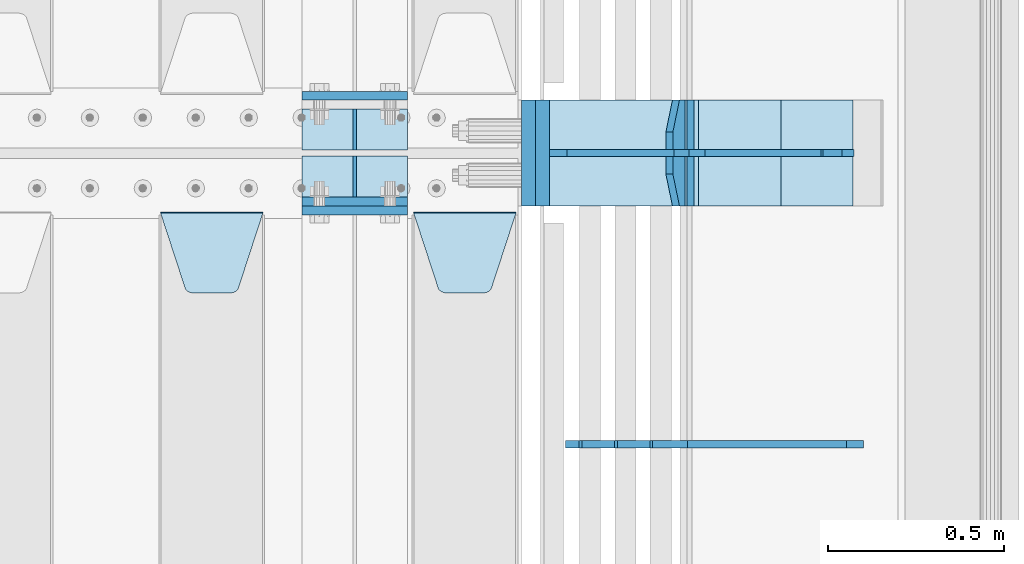
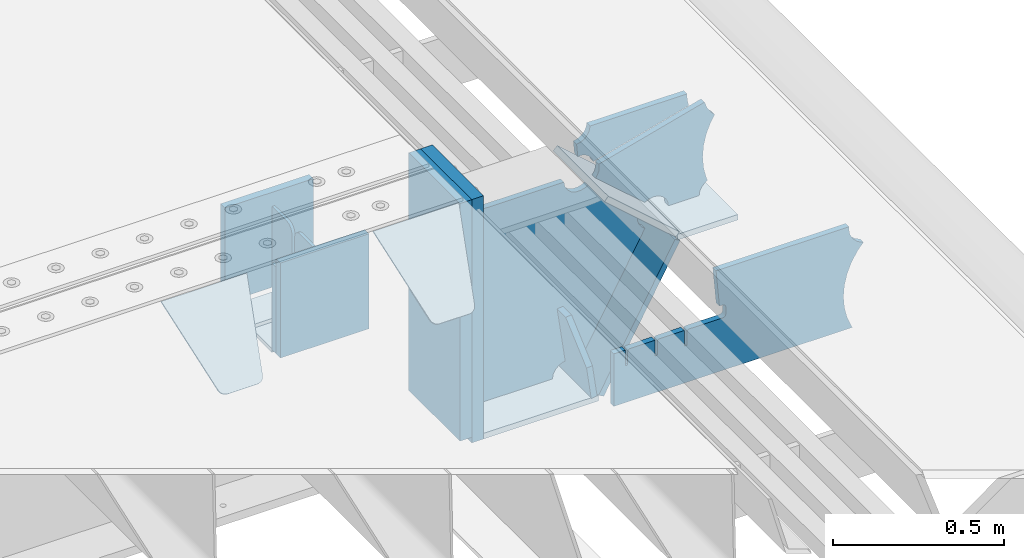
# One storey, part 191 of 219: 20 plates.
"""IFC2X3 building model written with IfcOpenShell, lengths in millimetres."""

from ifc_helpers import new_model, si_unit, frame, origin_with_axes, place, context, subcontext, project, spatial, faceted_brep, material, type_object, element, save


model = new_model("IFC2X3")

# Units and contexts
model_context = context("Model", 3, precision=1e-05, world=origin_with_axes())
body_context = subcontext(model_context, "Body", "Model", "MODEL_VIEW")
ifc_project = project(units=[si_unit("LENGTHUNIT", "METRE", prefix="MILLI"), si_unit("AREAUNIT", "SQUARE_METRE"), si_unit("VOLUMEUNIT", "CUBIC_METRE"), si_unit("MASSUNIT", "GRAM", prefix="KILO"), si_unit("TIMEUNIT", "SECOND"), si_unit("PLANEANGLEUNIT", "RADIAN"), si_unit("SOLIDANGLEUNIT", "STERADIAN"), si_unit("THERMODYNAMICTEMPERATUREUNIT", "DEGREE_CELSIUS"), si_unit("LUMINOUSINTENSITYUNIT", "LUMEN")], contexts=[model_context])

# Site, building, storey
site_placement = place(None, origin_with_axes())
site = spatial("IfcSite", under=ifc_project, at=site_placement, CompositionType="ELEMENT")
building_placement = place(site_placement, origin_with_axes())
building = spatial("IfcBuilding", under=site, at=building_placement, Name="Standard", CompositionType="ELEMENT")
storey_placement = place(building_placement, origin_with_axes())
storey = spatial("IfcBuildingStorey", under=building, at=storey_placement, Name="Undefined", CompositionType="ELEMENT", Elevation=0.0)

# Plates
ifc_material_1 = material(Name="STEEL/S355N")
plate_type_1 = type_object("IfcPlateType", PredefinedType="NOTDEFINED")
plate_1_placement = place(storey_placement, frame((13405.0, 29862.5, -339.999999999995), z_axis=(0.0, 0.0, 1.0), x_axis=(1.0, 0.0, 0.0)))
element("IfcPlate", 1, at=plate_1_placement, inside=storey, type_object=plate_type_1, material=ifc_material_1, context=body_context, shape_type="Brep", body=[
    faceted_brep([(0.0, -12.5, 0.0), (0.0, -12.5, 310.0), (0.0, 12.5, 310.0), (0.0, 12.5, 0.0), (300.0, -12.5, 310.0), (300.0, 12.5, 310.0), (300.0, -12.5, 0.0), (300.0, 12.5, 0.0)], [[[0, 1, 2, 3]], [[1, 4, 5, 2]], [[4, 6, 7, 5]], [[6, 0, 3, 7]], [[5, 7, 3, 2]], [[6, 4, 1, 0]]]),
])
for number, where, z_axis, x_axis in (
    (2, (13405.0, 29837.5, -340.000000000044), (0.0, 0.0, 1.0), (1.0, 0.0, 0.0)),
    (3, (13405.0, 30162.5, -340.000000000044), (0.0, 0.0, 1.0), (1.0, 0.0, 0.0)),
):
    element("IfcPlate", number, at=place(storey_placement, frame(where, z_axis=z_axis, x_axis=x_axis)), inside=storey, type_object=plate_type_1, material=ifc_material_1, context=body_context, shape_type="Brep", body=[
        faceted_brep([(0.0, -12.5, 0.0), (9.27684595808387e-10, -12.5, 340.0), (9.27684595808387e-10, 12.5, 340.0), (0.0, 12.5, 0.0), (300.0, -12.5, 340.0), (300.0, 12.5, 340.0), (300.0, -12.5, 0.0), (300.0, 12.5, 0.0)], [[[0, 1, 2, 3]], [[1, 4, 5, 2]], [[4, 6, 7, 5]], [[6, 0, 3, 7]], [[5, 7, 3, 2]], [[6, 4, 1, 0]]]),
    ])
plate_type_2 = type_object("IfcPlateType", PredefinedType="NOTDEFINED")
for number, where, z_axis, x_axis in (
    (4, (13405.0, 30008.0, -342.999999999995), (0.0, 1.0, 0.0), (1.0, 0.0, 0.0)),
    (5, (13405.0, 29992.0, -342.999999999995), (0.0, -1.0, 0.0), (1.0, 0.0, 0.0)),
):
    element("IfcPlate", number, at=place(storey_placement, frame(where, z_axis=z_axis, x_axis=x_axis)), inside=storey, type_object=plate_type_2, material=ifc_material_1, context=body_context, shape_type="Brep", body=[
        faceted_brep([(0.0, -7.0, 0.0), (0.0, -7.0, 117.0), (0.0, 7.0, 117.0), (0.0, 7.0, 0.0), (300.0, -7.0, 117.0), (300.0, 7.0, 117.0), (300.0, -7.0, 0.0), (300.0, 7.0, 0.0)], [[[0, 1, 2, 3]], [[1, 4, 5, 2]], [[4, 6, 7, 5]], [[6, 0, 3, 7]], [[5, 7, 3, 2]], [[6, 4, 1, 0]]]),
    ])
plate_type_3 = type_object("IfcPlateType", PredefinedType="NOTDEFINED")
for number, where, z_axis, x_axis in (
    (6, (13555.0, 30008.0, -29.9999999999945), (0.0, 0.0, -1.0), (0.0, 1.0, 0.0)),
    (7, (13555.0, 29992.0, -29.9999999999945), (0.0, 0.0, -1.0), (0.0, -1.0, 0.0)),
):
    element("IfcPlate", number, at=place(storey_placement, frame(where, z_axis=z_axis, x_axis=x_axis)), inside=storey, type_object=plate_type_3, material=ifc_material_1, context=body_context, shape_type="Brep", body=[
        faceted_brep([(0.0, -5.0, 30.0), (0.0, -5.0, 306.0), (0.0, 5.0, 306.0), (0.0, 5.0, 30.0), (117.0, -5.0, 306.0), (117.0, 5.0, 306.0), (117.0, -5.0, 0.0), (117.0, 5.0, 0.0), (30.0, -5.0, 0.0), (30.0, 5.0, 0.0), (24.7905546699913, -5.0, 0.455767409633758), (24.7905546699913, 5.0, 0.455767409633758), (19.7393957002278, -5.0, 1.80922137642275), (19.7393957002278, 5.0, 1.80922137642275), (15.0, -5.0, 4.01923788646684), (15.0, 5.0, 4.01923788646684), (10.7163717094008, -5.0, 7.01866670643066), (10.7163717094008, 5.0, 7.01866670643066), (7.01866670643358, -5.0, 10.7163717094038), (7.01866670643358, 5.0, 10.7163717094038), (4.01923788646673, -5.0, 15.0), (4.01923788646673, 5.0, 15.0), (1.80922137642483, -5.0, 19.7393957002299), (1.80922137642483, 5.0, 19.7393957002299), (0.455767409635882, -5.0, 24.7905546699921), (0.455767409635882, 5.0, 24.7905546699921)], [[[0, 1, 2, 3]], [[1, 4, 5, 2]], [[4, 6, 7, 5]], [[6, 8, 9, 7]], [[8, 10, 11, 9]], [[10, 12, 13, 11]], [[12, 14, 15, 13]], [[14, 16, 17, 15]], [[16, 18, 19, 17]], [[18, 20, 21, 19]], [[20, 22, 23, 21]], [[22, 24, 25, 23]], [[24, 0, 3, 25]], [[5, 7, 9, 11, 13, 15, 17, 19, 21, 23, 25, 3, 2]], [[24, 22, 20, 18, 16, 14, 12, 10, 8, 6, 4, 1, 0]]]),
    ])
plate_type_4 = type_object("IfcPlateType", PredefinedType="NOTDEFINED")
plate_2_placement = place(storey_placement, frame((13722.0, 29831.767766956, -1.76776695296758), z_axis=(0.0, -0.707106781186547, -0.707106781186548), x_axis=(1.0, 0.0, 0.0)))
element("IfcPlate", 8, at=plate_2_placement, inside=storey, type_object=plate_type_4, material=ifc_material_1, context=body_context, shape_type="Brep", body=[
    faceted_brep([(0.0, -2.5, 0.0), (69.345504679477, -2.5, 300.171731424834), (69.345504679477, 2.49999999999636, 300.171731424831), (0.0, 2.5, 0.0), (70.9274061199576, -2.50000000000364, 304.8974424154), (70.9274061199576, 2.49999999999636, 304.8974424154), (73.3818627772307, -2.50000000000364, 309.234538108532), (73.3818627772307, 2.49999999999636, 309.234538108532), (76.6187032999569, -2.50000000000364, 313.023683126106), (76.6187032999569, 2.49999999999636, 313.023683126106), (80.5190132704993, -2.50000000000364, 316.125672595372), (80.5190132704993, 2.49999999999636, 316.125672595372), (84.9395038596831, -2.50000000000364, 318.426546230476), (84.9395038596831, 2.5, 318.426546230479), (89.7177759439237, -2.50000000000364, 319.841774983277), (89.7177759439237, 2.5, 319.841774983281), (94.6782862926502, -2.50000000000364, 320.319366455078), (94.6782862926502, 2.49999999999636, 320.319366455078), (195.32171370735, -2.50000000000364, 320.319366455078), (195.32171370735, 2.49999999999636, 320.319366455078), (200.282224056076, -2.50000000000364, 319.841774983277), (200.282224056076, 2.5, 319.841774983281), (205.060496140317, -2.50000000000364, 318.426546230476), (205.060496140317, 2.49999999999636, 318.426546230476), (209.480986729501, -2.50000000000364, 316.125672595372), (209.480986729501, 2.49999999999636, 316.125672595372), (213.381296700043, -2.50000000000364, 313.023683126106), (213.381296700043, 2.49999999999272, 313.023683126106), (216.618137222769, -2.50000000000364, 309.234538108529), (216.618137222769, 2.49999999999636, 309.234538108525), (219.072593880042, -2.50000000000364, 304.8974424154), (219.072593880042, 2.49999999999636, 304.8974424154), (220.654495320523, -2.5, 300.171731424834), (220.654495320523, 2.49999999999636, 300.171731424831), (290.0, -2.50000000000364, 3.63797880709171e-12), (290.0, 2.49999999999636, 0.0)], [[[0, 1, 2, 3]], [[1, 4, 5, 2]], [[4, 6, 7, 5]], [[6, 8, 9, 7]], [[8, 10, 11, 9]], [[10, 12, 13, 11]], [[12, 14, 15, 13]], [[14, 16, 17, 15]], [[16, 18, 19, 17]], [[18, 20, 21, 19]], [[20, 22, 23, 21]], [[22, 24, 25, 23]], [[24, 26, 27, 25]], [[26, 28, 29, 27]], [[28, 30, 31, 29]], [[30, 32, 33, 31]], [[32, 34, 35, 33]], [[34, 0, 3, 35]], [[5, 7, 9, 11, 13, 15, 17, 19, 21, 23, 25, 27, 29, 31, 33, 35, 3, 2]], [[34, 32, 30, 28, 26, 24, 22, 20, 18, 16, 14, 12, 10, 8, 6, 4, 1, 0]]]),
])
plate_3_placement = place(storey_placement, frame((13005.0, 29831.767766956, -1.76776695296758), z_axis=(0.0, -0.707106781186547, -0.707106781186548), x_axis=(1.0, 0.0, 0.0)))
element("IfcPlate", 9, at=plate_3_placement, inside=storey, type_object=plate_type_4, material=ifc_material_1, context=body_context, shape_type="Brep", body=[
    faceted_brep([(0.0, -2.5, 0.0), (69.345504679477, -2.5, 300.171731424834), (69.345504679477, 2.49999999999636, 300.171731424831), (0.0, 2.5, 0.0), (70.9274061199576, -2.50000000000364, 304.8974424154), (70.9274061199576, 2.49999999999636, 304.8974424154), (73.3818627772307, -2.50000000000364, 309.234538108532), (73.3818627772307, 2.49999999999636, 309.234538108532), (76.6187032999569, -2.50000000000364, 313.023683126106), (76.6187032999569, 2.49999999999636, 313.023683126106), (80.5190132704993, -2.50000000000364, 316.125672595372), (80.5190132704993, 2.49999999999636, 316.125672595372), (84.9395038596831, -2.50000000000364, 318.426546230476), (84.9395038596831, 2.5, 318.426546230479), (89.7177759439237, -2.50000000000364, 319.841774983277), (89.7177759439237, 2.5, 319.841774983281), (94.6782862926502, -2.50000000000364, 320.319366455078), (94.6782862926502, 2.49999999999636, 320.319366455078), (195.32171370735, -2.50000000000364, 320.319366455078), (195.32171370735, 2.49999999999636, 320.319366455078), (200.282224056076, -2.50000000000364, 319.841774983277), (200.282224056076, 2.5, 319.841774983281), (205.060496140317, -2.50000000000364, 318.426546230476), (205.060496140317, 2.49999999999636, 318.426546230476), (209.480986729501, -2.50000000000364, 316.125672595372), (209.480986729501, 2.49999999999636, 316.125672595372), (213.381296700043, -2.50000000000364, 313.023683126106), (213.381296700043, 2.49999999999272, 313.023683126106), (216.618137222769, -2.50000000000364, 309.234538108529), (216.618137222769, 2.49999999999636, 309.234538108525), (219.072593880042, -2.50000000000364, 304.8974424154), (219.072593880042, 2.49999999999636, 304.8974424154), (220.654495320523, -2.5, 300.171731424834), (220.654495320523, 2.49999999999636, 300.171731424831), (290.0, -2.50000000000364, 3.63797880709171e-12), (290.0, 2.49999999999636, 0.0)], [[[0, 1, 2, 3]], [[1, 4, 5, 2]], [[4, 6, 7, 5]], [[6, 8, 9, 7]], [[8, 10, 11, 9]], [[10, 12, 13, 11]], [[12, 14, 15, 13]], [[14, 16, 17, 15]], [[16, 18, 19, 17]], [[18, 20, 21, 19]], [[20, 22, 23, 21]], [[22, 24, 25, 23]], [[24, 26, 27, 25]], [[26, 28, 29, 27]], [[28, 30, 31, 29]], [[30, 32, 33, 31]], [[32, 34, 35, 33]], [[34, 0, 3, 35]], [[5, 7, 9, 11, 13, 15, 17, 19, 21, 23, 25, 27, 29, 31, 33, 35, 3, 2]], [[34, 32, 30, 28, 26, 24, 22, 20, 18, 16, 14, 12, 10, 8, 6, 4, 1, 0]]]),
])
plate_type_5 = type_object("IfcPlateType", PredefinedType="NOTDEFINED")
plate_4_placement = place(storey_placement, frame((14481.0775331946, 30150.0000000017, -871.412303810021), z_axis=(0.0, -1.0, 0.0), x_axis=(-0.137902988002462, 0.0, 0.990445741017645)))
element("IfcPlate", 10, at=plate_4_placement, inside=storey, type_object=plate_type_5, material=ifc_material_1, context=body_context, shape_type="Brep", body=[
    faceted_brep([(0.0, -10.0, 0.0), (-1.97815097635612e-10, -10.0, 300.0), (-1.97815097635612e-10, 10.0000000000018, 300.0), (0.0, 10.0, 0.0), (115.0, -10.0, 300.0), (115.0, 10.0, 300.0), (250.0, -10.0, 210.0), (250.0, 10.0, 210.0), (250.0, -10.0, 90.0), (250.0, 10.0, 90.0), (115.0, -10.0, -1.09139364212751e-10), (115.0, 10.0, -1.09139364212751e-10)], [[[0, 1, 2, 3]], [[1, 4, 5, 2]], [[4, 6, 7, 5]], [[6, 8, 9, 7]], [[8, 10, 11, 9]], [[10, 0, 3, 11]], [[5, 7, 9, 11, 3, 2]], [[10, 8, 6, 4, 1, 0]]]),
])
plate_type_6 = type_object("IfcPlateType", PredefinedType="NOTDEFINED")
plate_5_placement = place(storey_placement, frame((14509.9988298913, 30000.0000000001, -179.999999999866), z_axis=(0.0, 0.0, -1.0), x_axis=(-1.0, 0.0, 0.0)))
element("IfcPlate", 11, at=plate_5_placement, inside=storey, type_object=plate_type_6, material=ifc_material_1, context=body_context, shape_type="Brep", body=[
    faceted_brep([(46.0258547361573, 10.0, 641.078828352488), (73.3015011074949, 10.0000000000109, 445.179898435785), (73.3015011074949, -9.99999999998545, 445.179898435785), (46.0258547361573, -10.0, 641.078828352488), (53.4925862871423, 10.0000000000109, 442.421838675736), (53.4925862871423, -9.99999999998545, 442.421838675736), (25.7820501124042, 10.0, 641.444230671291), (25.7820501124042, -10.0, 641.444230671291), (54.66525031116, 10.0, 642.447174185377), (54.66525031116, -10.0, 642.447174185377), (68.6036632070372, -10.0, 649.549150281387), (68.6036632070372, 10.0, 649.549150281387), (79.66525031116, -10.0, 660.610737385511), (79.66525031116, 10.0, 660.610737385511), (86.7672264071698, -10.0, 674.549150281387), (86.7672264071698, 10.0, 674.549150281387), (89.2144005924129, -10.0, 690.0), (89.2144005924129, 10.0, 690.0), (353.0, -10.0, 690.0), (353.0, 10.0, 690.0), (355.447174185243, -10.0, 674.549150281253), (355.447174185243, 10.0, 674.549150281253), (362.549150281253, -10.0, 660.610737385376), (362.549150281253, 10.0, 660.610737385376), (373.610737385376, -10.0, 649.549150281253), (373.610737385376, 10.0, 649.549150281253), (387.549150281253, -10.0, 642.447174185242), (387.549150281253, 10.0, 642.447174185242), (403.0, -10.0, 640.0), (403.0, 10.0, 640.0), (403.0, -10.0, 50.0), (403.0, 10.0, 50.0), (387.549150281253, -10.0, 47.5528258147577), (387.549150281253, 10.0, 47.5528258147577), (373.610737385376, -10.0, 40.4508497187474), (373.610737385376, 10.0, 40.4508497187474), (362.549150281253, -10.0, 29.3892626146236), (362.549150281253, 10.0, 29.3892626146236), (355.447174185243, -10.0, 15.4508497187474), (355.447174185243, 10.0, 15.4508497187474), (353.0, -10.0, 0.0), (353.0, 10.0, 0.0), (50.0, -10.0, 0.0), (50.0, 10.0, 0.0), (47.0349915316328, -10.0, 16.9620037619133), (47.0349915316328, 10.0, 16.9620037619133), (38.4916171352343, -10.0, 31.9123081320451), (38.4916171352343, 10.0, 31.9123081320451), (25.3831239081501, -10.0, 43.0778019479116), (25.3831239081501, 10.0, 43.0778019479116), (9.26418358741648, -10.0, 49.1342538608113), (9.26418358741648, 10.0, 49.1342538608113), (-7.95349204488593, -10.0, 49.363366622344), (-7.95349204488593, 10.0, 49.363366622344), (-24.2278808265401, -10.0, 43.7379673813837), (-24.2278808265401, 10.0, 43.7379673813837), (-37.6288347353438, -10.0, 32.9252303934259), (-37.6288347353438, 10.0, 32.9252303934259), (-210.371165264656, -10.0, 184.074769606574), (-210.371165264656, 10.0, 184.074769606574), (-202.382363280569, -10.0, 196.529747922069), (-202.382363280569, 10.0, 196.529747922069), (-198.388707244047, -10.0, 210.777489969227), (-198.388707244047, 10.0, 210.777489969227), (-198.739957464426, -10.0, 225.570193077959), (-198.739957464426, 10.0, 225.570193077959), (-203.40535180681, -10.0, 239.612327446012), (-203.40535180681, 10.0, 239.612327446012), (-211.976299808361, -10.0, 251.674097313455), (-211.976299808361, 10.0, 251.674097313455), (-223.702166612962, -10.0, 260.699145216992), (-223.702166612962, 10.0, 260.699145216992), (-9.29783338703783, -10.0, 646.300854783008), (-9.29783338703783, 10.0, 646.300854783008), (6.98069453597964, -10.0, 640.647282345602), (6.98069453597964, 10.0, 640.647282345602), (24.2117663163681, -10.0, 640.855891896051), (24.2117663163681, 10.0, 640.855891896051)], [[[0, 1, 2, 3]], [[4, 5, 2, 1]], [[6, 7, 5, 4]], [[8, 9, 10, 11]], [[11, 10, 12, 13]], [[13, 12, 14, 15]], [[15, 14, 16, 17]], [[18, 19, 17, 16]], [[18, 20, 21, 19]], [[20, 22, 23, 21]], [[22, 24, 25, 23]], [[24, 26, 27, 25]], [[26, 28, 29, 27]], [[28, 30, 31, 29]], [[30, 32, 33, 31]], [[32, 34, 35, 33]], [[34, 36, 37, 35]], [[36, 38, 39, 37]], [[38, 40, 41, 39]], [[40, 42, 43, 41]], [[42, 44, 45, 43]], [[44, 46, 47, 45]], [[46, 48, 49, 47]], [[48, 50, 51, 49]], [[50, 52, 53, 51]], [[52, 54, 55, 53]], [[54, 56, 57, 55]], [[56, 58, 59, 57]], [[58, 60, 61, 59]], [[60, 62, 63, 61]], [[62, 64, 65, 63]], [[64, 66, 67, 65]], [[66, 68, 69, 67]], [[68, 70, 71, 69]], [[70, 72, 73, 71]], [[72, 74, 75, 73]], [[74, 76, 77, 75]], [[1, 0, 8, 11, 13, 15, 17, 19, 21, 23, 25, 27, 29, 31, 33, 35, 37, 39, 41, 43, 45, 47, 49, 51, 53, 55, 57, 59, 61, 63, 65, 67, 69, 71, 73, 75, 77, 6, 4]], [[9, 8, 0, 3]], [[76, 74, 72, 70, 68, 66, 64, 62, 60, 58, 56, 54, 52, 50, 48, 46, 44, 42, 40, 38, 36, 34, 32, 30, 28, 26, 24, 22, 20, 18, 16, 14, 12, 10, 9, 3, 2, 5, 7]], [[77, 76, 7, 6]]]),
])
plate_type_7 = type_object("IfcPlateType", PredefinedType="NOTDEFINED")
plate_6_placement = place(storey_placement, frame((15050.9988502512, 29999.9999999993, -28.9999913318487), z_axis=(0.260769276985653, 0.0, -0.965401151946889), x_axis=(-0.965401151946889, 0.0, -0.260769276985654)))
element("IfcPlate", 12, at=plate_6_placement, inside=storey, type_object=plate_type_7, material=ifc_material_1, context=body_context, shape_type="Brep", body=[
    faceted_brep([(183.436474692322, 10.0, 275.852500330424), (184.918388609056, 10.0, 264.417843531324), (184.918388609056, -10.0, 264.417843531324), (183.436474692322, -10.0, 275.852500330424), (183.794583267612, 10.0, 224.576469334609), (183.794583267612, -10.0, 224.576469334609), (176.452049775835, 10.0, 185.401410454623), (176.452049775835, -10.0, 185.401410454623), (163.071585676769, 10.0, 147.857286855559), (163.071585676769, -10.0, 147.857286855559), (143.982662403743, 10.0, 112.868559462228), (143.982662403743, -10.0, 112.868559462228), (119.655312600249, 10.0, 81.2967668639835), (119.655312600249, -10.0, 81.2967668639835), (100.960891712748, 10.0, 63.6280409830915), (100.960891712748, -10.0, 63.6280409830915), (194.486836975902, -10.0, 278.751956446687), (207.178624553371, -10.0, 286.650994937515), (207.178624553371, 10.0, 286.650994937515), (194.486836975902, 10.0, 278.751956446687), (216.968013469443, -10.0, 297.948965801396), (216.968013469443, 10.0, 297.948965801396), (222.979925232859, -10.0, 311.635937633766), (222.979925232859, 10.0, 311.635937633766), (323.381647032762, -10.0, 284.515917834984), (323.381647032762, 10.0, 284.515917834984), (321.720617177332, -10.0, 268.853198956861), (321.720617177332, 10.0, 268.853198956861), (325.01434448114, -10.0, 253.450889283182), (325.01434448114, 10.0, 253.450889283182), (332.935986082481, -10.0, 239.837389469555), (332.935986082481, 10.0, 239.837389469555), (344.699462330087, -10.0, 229.363593146937), (344.699462330087, 10.0, 229.363593146937), (359.137460970805, -10.0, 223.068835162201), (359.137460970805, 10.0, 223.068835162201), (374.817271777683, -10.0, 221.57775639289), (374.817271777683, 10.0, 221.57775639289), (390.182952880858, -10.0, 225.038330078125), (390.182952880858, 10.0, 225.038330078125), (512.909060513028, -10.0, 41.5599003357015), (512.909060513028, 10.0, 41.5599003357015), (503.648024844581, -10.0, 33.5643666747674), (503.648024844581, 10.0, 33.5643666747674), (496.606064569702, -10.0, 23.5590612989986), (496.606064569702, 10.0, 23.5590612989986), (492.204839143929, -10.0, 12.1430832451083), (492.204839143929, 10.0, 12.1430832451083), (490.707885742186, -10.0, 3.79714037990198e-10), (490.707885742186, 10.0, 3.79714037990198e-10), (119.999999999998, -10.0, 9.27684595808387e-11), (119.999999999998, 10.0, 9.27684595808387e-11), (117.226254779109, -10.0, 25.651611849215), (117.226254779109, 10.0, 25.651611849215), (109.033246825658, -10.0, 50.1173731020972), (109.033246825658, 10.0, 50.1173731020972)], [[[0, 1, 2, 3]], [[4, 5, 2, 1]], [[6, 7, 5, 4]], [[8, 9, 7, 6]], [[10, 11, 9, 8]], [[12, 13, 11, 10]], [[14, 15, 13, 12]], [[16, 17, 18, 19]], [[17, 20, 21, 18]], [[20, 22, 23, 21]], [[22, 24, 25, 23]], [[24, 26, 27, 25]], [[26, 28, 29, 27]], [[28, 30, 31, 29]], [[30, 32, 33, 31]], [[32, 34, 35, 33]], [[34, 36, 37, 35]], [[36, 38, 39, 37]], [[38, 40, 41, 39]], [[40, 42, 43, 41]], [[42, 44, 45, 43]], [[44, 46, 47, 45]], [[46, 48, 49, 47]], [[48, 50, 51, 49]], [[50, 52, 53, 51]], [[52, 54, 55, 53]], [[10, 8, 6, 4, 1, 0, 19, 18, 21, 23, 25, 27, 29, 31, 33, 35, 37, 39, 41, 43, 45, 47, 49, 51, 53, 55, 14, 12]], [[16, 19, 0, 3]], [[54, 52, 50, 48, 46, 44, 42, 40, 38, 36, 34, 32, 30, 28, 26, 24, 22, 20, 17, 16, 3, 2, 5, 7, 9, 11, 13, 15]], [[55, 54, 15, 14]]]),
])
plate_type_8 = type_object("IfcPlateType", PredefinedType="NOTDEFINED")
plate_7_placement = place(storey_placement, frame((14522.2260590443, 30149.9999999993, -177.219372761326), z_axis=(0.752414935148685, 0.0, -0.658689430130164), x_axis=(0.0, -1.0, 0.0)))
element("IfcPlate", 13, at=plate_7_placement, inside=storey, type_object=plate_type_8, material=ifc_material_1, context=body_context, shape_type="Brep", body=[
    faceted_brep([(0.0, -10.0, 0.0), (1.09139364212751e-10, -10.0000000000018, 319.999999999998), (1.09139364212751e-10, 10.0, 319.999999999998), (0.0, 10.0, 0.0), (300.0, -10.0000000000018, 319.999999999998), (300.0, 10.0, 319.999999999998), (300.0, -10.0, 6.73026079311967e-11), (300.0, 10.0, 6.73026079311967e-11)], [[[0, 1, 2, 3]], [[1, 4, 5, 2]], [[4, 6, 7, 5]], [[6, 0, 3, 7]], [[5, 7, 3, 2]], [[6, 4, 1, 0]]]),
])
plate_8_placement = place(storey_placement, frame((14763.0007288108, 30150.0000000001, -408.004820491625), z_axis=(-0.484064236150486, 0.0, -0.87503246527203), x_axis=(0.0, -1.0, 0.0)))
element("IfcPlate", 14, at=plate_8_placement, inside=storey, type_object=plate_type_8, material=ifc_material_1, context=body_context, shape_type="Brep", body=[
    faceted_brep([(0.0, -10.0, 0.0), (3.86513420380652e-07, -10.0, 533.528442382813), (3.86513420380652e-07, 9.99999999999818, 533.528442382814), (0.0, 10.0, 0.0), (300.003295898438, -10.0, 533.549133300783), (300.003295898438, 9.99999999999818, 533.549133300783), (300.0, -10.0, 6.73026079311967e-11), (300.0, 10.0, 6.73026079311967e-11)], [[[0, 1, 2, 3]], [[1, 4, 5, 2]], [[4, 6, 7, 5]], [[6, 0, 3, 7]], [[5, 7, 3, 2]], [[6, 4, 1, 0]]]),
])
plate_9_placement = place(storey_placement, frame((14106.9988298913, 30150.0000000001, -879.999999999866), z_axis=(0.0, -1.0, 0.0), x_axis=(1.0, 0.0, 0.0)))
element("IfcPlate", 15, at=plate_9_placement, inside=storey, type_object=plate_type_8, material=ifc_material_1, context=body_context, shape_type="Brep", body=[
    faceted_brep([(0.0, -10.0, 0.0), (-1.97815097635612e-10, -10.0, 300.0), (-1.97815097635612e-10, 10.0000000000018, 300.0), (0.0, 10.0, 0.0), (389.0, -10.0, 300.0), (389.0, 10.0, 300.0), (389.0, -10.0, 0.0), (389.0, 10.0, 0.0)], [[[0, 1, 2, 3]], [[1, 4, 5, 2]], [[4, 6, 7, 5]], [[6, 0, 3, 7]], [[5, 7, 3, 2]], [[6, 4, 1, 0]]]),
])
plate_type_9 = type_object("IfcPlateType", PredefinedType="NOTDEFINED")
plate_10_placement = place(storey_placement, frame((14966.9988298913, 30149.9999999993, -397.999999999763), z_axis=(-1.0, 0.0, 0.0), x_axis=(0.0, -1.0, 0.0)))
element("IfcPlate", 16, at=plate_10_placement, inside=storey, type_object=plate_type_9, material=ifc_material_1, context=body_context, shape_type="Brep", body=[
    faceted_brep([(0.0, -10.0, 0.0), (4.65661287307739e-10, -10.0, 204.0), (4.65661287307739e-10, 10.0, 204.0), (0.0, 10.0, 0.0), (300.0, -10.0, 204.0), (300.0, 10.0, 204.0), (300.0, -10.0, 6.73026079311967e-11), (300.0, 10.0, 6.73026079311967e-11)], [[[0, 1, 2, 3]], [[1, 4, 5, 2]], [[4, 6, 7, 5]], [[6, 0, 3, 7]], [[5, 7, 3, 2]], [[6, 4, 1, 0]]]),
])
ifc_material_2 = material()
plate_type_10 = type_object("IfcPlateType", PredefinedType="NOTDEFINED")
plate_11_placement = place(storey_placement, frame((14047.0, 30150.0, -870.0), z_axis=(0.0, 0.0, 1.0), x_axis=(0.0, -1.0, 0.0)))
element("IfcPlate", 17, at=plate_11_placement, inside=storey, type_object=plate_type_10, material=ifc_material_2, context=body_context, shape_type="Brep", body=[
    faceted_brep([(0.0, -20.0, 0.0), (0.0, -20.0, 850.0), (0.0, 20.0, 850.0), (0.0, 20.0, 0.0), (300.0, -20.0, 850.0), (300.0, 20.0, 850.0), (300.0, -20.0, -1.81898940354586e-12), (300.0, 20.0, -1.81898940354586e-12)], [[[0, 1, 2, 3]], [[1, 4, 5, 2]], [[4, 6, 7, 5]], [[6, 0, 3, 7]], [[5, 7, 3, 2]], [[6, 4, 1, 0]]]),
])
plate_12_placement = place(storey_placement, frame((14086.9988298906, 30150.0, -889.999999999995), z_axis=(0.0, 0.0, 1.0), x_axis=(0.0, -1.0, 0.0)))
element("IfcPlate", 18, at=plate_12_placement, inside=storey, type_object=plate_type_10, material=ifc_material_2, context=body_context, shape_type="Brep", body=[
    faceted_brep([(0.0, -20.0, 0.0), (0.0, -20.0, 870.0), (0.0, 20.0, 870.0), (0.0, 20.0, 0.0), (300.0, -20.0, 870.0), (300.0, 20.0, 870.0), (300.0, -20.0, -1.81898940354586e-12), (300.0, 20.0, -1.81898940354586e-12)], [[[0, 1, 2, 3]], [[1, 4, 5, 2]], [[4, 6, 7, 5]], [[6, 0, 3, 7]], [[5, 7, 3, 2]], [[6, 4, 1, 0]]]),
])
plate_type_11 = type_object("IfcPlateType", PredefinedType="NOTDEFINED")
plate_13_placement = place(storey_placement, frame((15045.9988298906, 30000.0, -9.99999999999716), z_axis=(0.0, 0.0, -1.0), x_axis=(-1.0, 0.0, 0.0)))
element("IfcPlate", 19, at=plate_13_placement, inside=storey, type_object=plate_type_11, material=ifc_material_1, context=body_context, shape_type="Brep", body=[
    faceted_brep([(164.157641141066, -10.0, 44.1844865875018), (486.718340840864, -10.0, 131.004562768382), (486.718340840864, 10.0, 131.004562768382), (164.157641141066, 10.0, 44.1844865875018), (492.179177700769, -10.0, 118.185717565315), (492.179177700769, 10.0, 118.185717565315), (500.965368826704, -10.0, 107.371542744776), (500.965368826704, 10.0, 107.371542744776), (512.394601349042, -10.0, 99.4018391429503), (512.394601349042, 10.0, 99.4018391429503), (525.579310641862, -10.0, 94.8955133209048), (525.579310641862, 10.0, 94.8955133209048), (539.495606295339, -10.0, 94.2025148824028), (539.495606295339, 10.0, 94.2025148824028), (543.504393704661, -10.0, 49.7974851175972), (543.504393704661, 10.0, 49.7974851175972), (529.167086307516, -10.0, 46.3176139481669), (529.167086307516, 10.0, 46.3176139481669), (516.469507120331, -10.0, 38.8049999196639), (516.469507120331, 10.0, 38.8049999196639), (506.517198234544, -10.0, 27.9137449599276), (506.517198234544, 10.0, 27.9137449599276), (500.176678867561, -10.0, 14.592119649441), (500.176678867561, 10.0, 14.592119649441), (498.0, -10.0, 0.0), (498.0, 10.0, 0.0), (170.0, -10.0, 0.0), (170.0, 10.0, 0.0), (169.632873911985, -10.0, 11.1663820622718), (169.632873911985, 10.0, 11.1663820622718), (168.533081313404, -10.0, 22.2845350637931), (168.533081313404, 10.0, 22.2845350637931), (166.705372351957, -10.0, 33.3064382514178), (166.705372351957, 10.0, 33.3064382514178)], [[[0, 1, 2, 3]], [[1, 4, 5, 2]], [[4, 6, 7, 5]], [[6, 8, 9, 7]], [[8, 10, 11, 9]], [[10, 12, 13, 11]], [[12, 14, 15, 13]], [[14, 16, 17, 15]], [[16, 18, 19, 17]], [[18, 20, 21, 19]], [[20, 22, 23, 21]], [[22, 24, 25, 23]], [[24, 26, 27, 25]], [[26, 28, 29, 27]], [[28, 30, 31, 29]], [[30, 32, 33, 31]], [[32, 0, 3, 33]], [[5, 7, 9, 11, 13, 15, 17, 19, 21, 23, 25, 27, 29, 31, 33, 3, 2]], [[32, 30, 28, 26, 24, 22, 20, 18, 16, 14, 12, 10, 8, 6, 4, 1, 0]]]),
])
plate_type_12 = type_object("IfcPlateType", PredefinedType="NOTDEFINED")
plate_14_placement = place(storey_placement, frame((14992.9182339676, 29174.9992828369, -374.002067436516), z_axis=(0.0, 0.0, 1.0), x_axis=(-1.0, 0.0, 0.0)))
element("IfcPlate", 20, at=plate_14_placement, inside=storey, type_object=plate_type_12, material=ifc_material_1, context=body_context, shape_type="Brep", body=[
    faceted_brep([(801.919404066546, -10.0, 188.0), (801.919404066546, 10.0, 188.0), (801.919404066546, 10.0, 132.002067436952), (801.919404066546, -9.99999999999636, 132.002067436952), (793.919404066546, 10.0, 132.002067436952), (793.919404066546, -9.99999999999636, 132.002067436952), (793.919404066546, 10.0, 180.002067436952), (793.919404066546, -10.0, 180.002067436952), (793.527856196908, 10.0, 182.474203391951), (793.527856196908, -10.0, 182.474203391951), (792.391540021546, 10.0, 184.704349455291), (792.391540021546, -10.0, 184.704349455291), (790.621686084885, 10.0, 186.474203391951), (790.621686084885, -10.0, 186.474203391951), (788.391540021546, 10.0, 187.610519567313), (788.391540021546, -10.0, 187.610519567313), (785.919404066546, -10.0, 188.002067436952), (785.919404066546, 10.0, 188.0), (841.0, -10.0, 188.0), (841.0, -10.0, 0.0), (841.0, 10.0, 0.0), (841.0, 10.0, 188.0), (33.3619566736033, -10.0, 0.0), (33.3619566736033, 10.0, 0.0), (36.2350612208174, -10.0, 4.68848050267013), (36.2350612208174, 10.0, 4.68848050267013), (51.487759215941, -10.0, 41.5117508652784), (51.487759215941, 10.0, 41.5117508652784), (60.792242588137, -10.0, 80.2677133162964), (60.792242588137, 10.0, 80.2677133162964), (63.9194040769726, -10.0, 120.002067436515), (63.9194040769726, 10.0, 120.002067436515), (60.792242588137, -10.0, 159.736421556734), (60.792242588137, 10.0, 159.736421556734), (51.487759215941, -10.0, 198.492384007752), (51.487759215941, 10.0, 198.492384007752), (36.2350612208174, -10.0, 235.31565437036), (36.2350612208174, 10.0, 235.31565437036), (15.4097206482093, -10.0, 269.299521518803), (15.4097206482093, 10.0, 269.299521518803), (-3.35474438098936, -10.0, 291.269887256574), (-3.35474438098936, 10.0, 291.269887256574), (-2.36881039375294, -10.0, 291.426043859339), (-2.36881039375294, 10.0, 291.426043859339), (17.1449676604734, -10.0, 301.368810393754), (17.1449676604734, 10.0, 301.368810393754), (32.6311896062471, -10.0, 316.855032339527), (32.6311896062471, 10.0, 316.855032339527), (42.5739561406608, -10.0, 336.368810393754), (42.5739561406608, 10.0, 336.368810393754), (46.0, -10.0, 358.0), (46.0, 10.0, 358.0), (45.0495205499192, -10.0, 364.001091067617), (45.0495205499192, 10.0, 364.001091067617), (495.040008544922, -10.0, 364.010009765625), (495.040008544922, 10.0, 364.010009765625), (483.600036621094, -10.0, 233.759994506836), (483.600036621094, 10.0, 233.759994506836), (472.0, -10.0, 233.759994506836), (472.0, 10.0, 233.759994506836), (468.909830056251, -10.0, 233.270559669787), (468.909830056251, 10.0, 233.270559669787), (466.122147477075, -10.0, 231.850164450585), (466.122147477075, 10.0, 231.850164450585), (463.909830056251, -10.0, 229.637847029761), (463.909830056251, 10.0, 229.637847029761), (462.489434837049, -10.0, 226.850164450585), (462.489434837049, 10.0, 226.850164450585), (462.0, -10.0, 223.759994506836), (462.0, 10.0, 223.759994506836), (462.0, -10.0, 198.0), (462.0, 10.0, 198.0), (462.489434837049, -10.0, 194.909830056251), (462.489434837049, 10.0, 194.909830056251), (463.909830056251, -10.0, 192.122147477075), (463.909830056251, 10.0, 192.122147477075), (466.122147477075, -10.0, 189.909830056251), (466.122147477075, 10.0, 189.909830056251), (468.909830056251, -10.0, 188.489434837048), (468.909830056251, 10.0, 188.489434837048), (472.0, -10.0, 188.0), (472.0, 10.0, 188.0), (585.919404066546, -10.0, 188.002067436952), (585.919404066546, 10.0, 188.0), (588.391540021546, -10.0, 187.610519567313), (588.391540021546, 10.0, 187.610519567313), (590.621686084885, -10.0, 186.474203391951), (590.621686084885, 10.0, 186.474203391951), (592.391540021546, -10.0, 184.704349455291), (592.391540021546, 10.0, 184.704349455291), (593.527856196908, -10.0, 182.474203391951), (593.527856196908, 10.0, 182.474203391951), (593.919404066546, -10.0, 180.002067436952), (593.919404066546, 10.0, 180.002067436952), (593.919404066546, -10.0, 132.002067436952), (593.919404066546, 10.0, 132.002067436952), (601.919404066546, -10.0, 132.002067436952), (601.919404066546, 10.0, 132.002067436952), (601.919404066546, -10.0, 188.0), (601.919404066546, 10.0, 188.0), (685.919404066546, -10.0, 188.002067436952), (685.919404066546, 10.0, 188.0), (688.391540021546, -10.0, 187.610519567313), (688.391540021546, 10.0, 187.610519567313), (690.621686084885, -10.0, 186.474203391951), (690.621686084885, 10.0, 186.474203391951), (692.391540021546, -10.0, 184.704349455291), (692.391540021546, 10.0, 184.704349455291), (693.527856196908, -10.0, 182.474203391951), (693.527856196908, 10.0, 182.474203391951), (693.919404066546, -10.0, 180.002067436952), (693.919404066546, 10.0, 180.002067436952), (693.919404066546, -10.0, 132.002067436952), (693.919404066546, 10.0, 132.002067436952), (701.919404066546, -10.0, 132.002067436952), (701.919404066546, 10.0, 132.002067436952), (701.919404066546, -10.0, 188.0), (701.919404066546, 10.0, 188.0)], [[[0, 1, 2, 3]], [[3, 2, 4, 5]], [[5, 4, 6, 7]], [[7, 6, 8, 9]], [[9, 8, 10, 11]], [[11, 10, 12, 13]], [[13, 12, 14, 15]], [[16, 15, 14, 17]], [[18, 19, 20, 21]], [[20, 19, 22, 23]], [[22, 24, 25, 23]], [[26, 27, 25, 24]], [[28, 29, 27, 26]], [[30, 31, 29, 28]], [[32, 33, 31, 30]], [[34, 35, 33, 32]], [[36, 37, 35, 34]], [[38, 39, 37, 36]], [[39, 38, 40, 41]], [[40, 42, 43, 41]], [[44, 45, 43, 42]], [[46, 47, 45, 44]], [[48, 49, 47, 46]], [[50, 51, 49, 48]], [[52, 53, 51, 50]], [[54, 55, 53, 52]], [[54, 56, 57, 55]], [[56, 58, 59, 57]], [[58, 60, 61, 59]], [[60, 62, 63, 61]], [[62, 64, 65, 63]], [[64, 66, 67, 65]], [[66, 68, 69, 67]], [[68, 70, 71, 69]], [[70, 72, 73, 71]], [[72, 74, 75, 73]], [[74, 76, 77, 75]], [[76, 78, 79, 77]], [[78, 80, 81, 79]], [[81, 80, 82, 83]], [[82, 84, 85, 83]], [[86, 87, 85, 84]], [[88, 89, 87, 86]], [[90, 91, 89, 88]], [[92, 93, 91, 90]], [[94, 95, 93, 92]], [[96, 97, 95, 94]], [[98, 99, 97, 96]], [[99, 98, 100, 101]], [[100, 102, 103, 101]], [[104, 105, 103, 102]], [[106, 107, 105, 104]], [[108, 109, 107, 106]], [[110, 111, 109, 108]], [[112, 113, 111, 110]], [[114, 115, 113, 112]], [[116, 117, 115, 114]], [[117, 116, 16, 17]], [[12, 10, 8, 6, 4, 2, 1, 21, 20, 23, 25, 27, 29, 31, 33, 35, 37, 39, 41, 43, 45, 47, 49, 51, 53, 55, 57, 59, 61, 63, 65, 67, 69, 71, 73, 75, 77, 79, 81, 83, 85, 87, 89, 91, 93, 95, 97, 99, 101, 103, 105, 107, 109, 111, 113, 115, 117, 17, 14]], [[18, 21, 1, 0]], [[116, 114, 112, 110, 108, 106, 104, 102, 100, 98, 96, 94, 92, 90, 88, 86, 84, 82, 80, 78, 76, 74, 72, 70, 68, 66, 64, 62, 60, 58, 56, 54, 52, 50, 48, 46, 44, 42, 40, 38, 36, 34, 32, 30, 28, 26, 24, 22, 19, 18, 0, 3, 5, 7, 9, 11, 13, 15, 16]]]),
])

save(model, "model.ifc")
